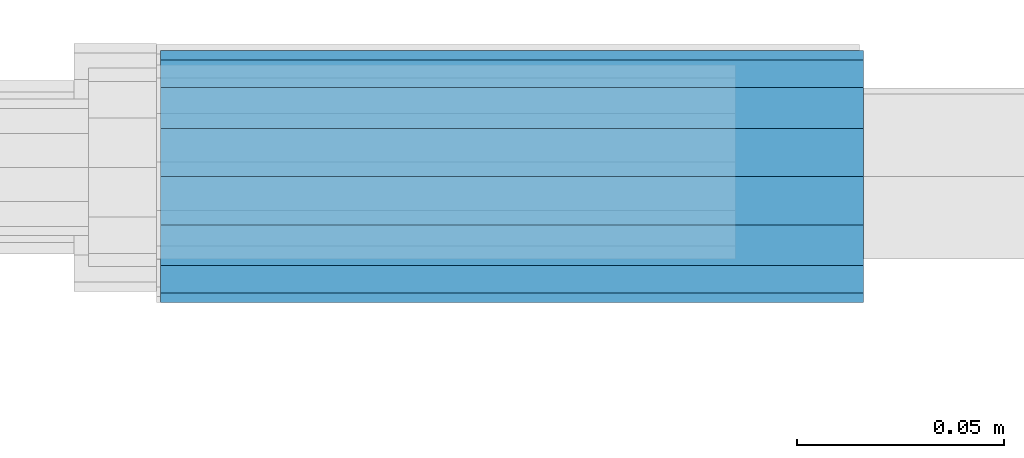
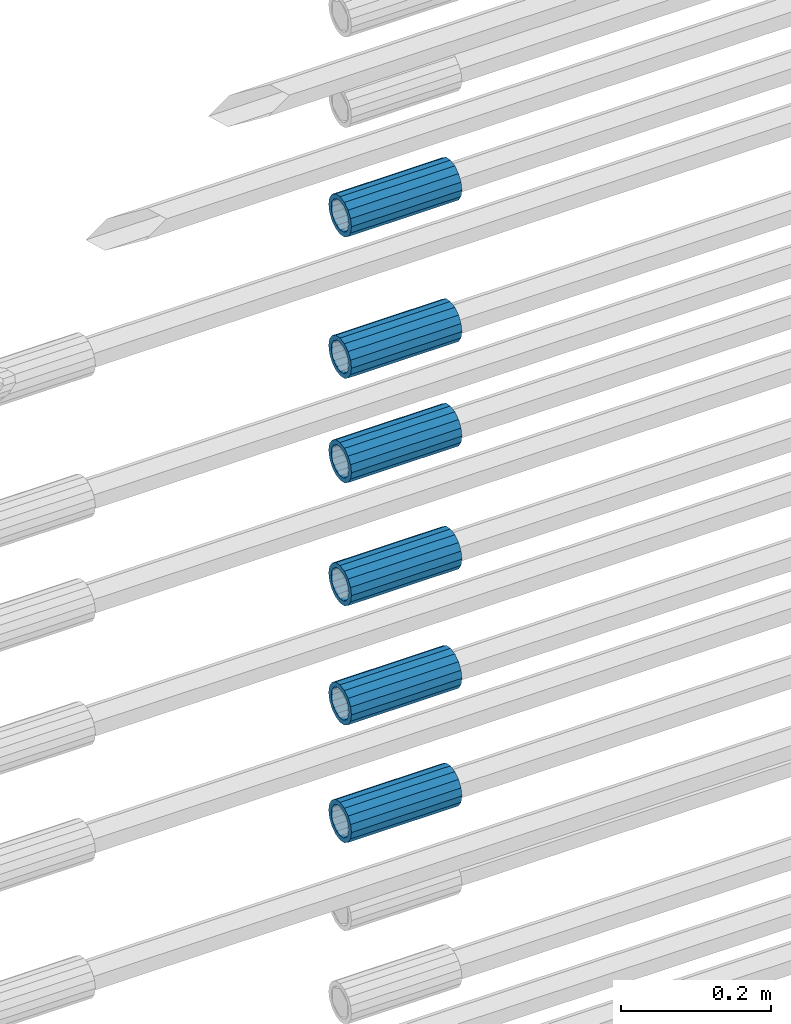
# One storey, part 13 of 119: 6 beams.
"""IFC2X3 building model written with IfcOpenShell, lengths in millimetres."""

from ifc_helpers import new_model, si_unit, frame, origin_with_axes, place, context, subcontext, project, spatial, faceted_brep, material, type_object, element, save


model = new_model("IFC2X3")

# Units and contexts
model_context = context("Model", 3, precision=1e-05, world=origin_with_axes())
body_context = subcontext(model_context, "Body", "Model", "MODEL_VIEW")
ifc_project = project(units=[si_unit("LENGTHUNIT", "METRE", prefix="MILLI"), si_unit("AREAUNIT", "SQUARE_METRE"), si_unit("VOLUMEUNIT", "CUBIC_METRE"), si_unit("MASSUNIT", "GRAM", prefix="KILO"), si_unit("TIMEUNIT", "SECOND"), si_unit("PLANEANGLEUNIT", "RADIAN"), si_unit("SOLIDANGLEUNIT", "STERADIAN"), si_unit("THERMODYNAMICTEMPERATUREUNIT", "DEGREE_CELSIUS"), si_unit("LUMINOUSINTENSITYUNIT", "LUMEN")], contexts=[model_context])

# Site, building, storey
site_placement = place(None, origin_with_axes())
site = spatial("IfcSite", under=ifc_project, at=site_placement, CompositionType="ELEMENT")
building_placement = place(site_placement, origin_with_axes())
building = spatial("IfcBuilding", under=site, at=building_placement, Name="Undefined", CompositionType="ELEMENT")
storey_placement = place(building_placement, origin_with_axes())
storey = spatial("IfcBuildingStorey", under=building, at=storey_placement, Name="Undefined", CompositionType="ELEMENT", Elevation=0.0)

# Beams
ifc_material = material(Name="STEEL/S275")
beam_type = type_object("IfcBeamType", PredefinedType="NOTDEFINED")
beam_1_placement = place(storey_placement, frame((2032020.00007889, 6206399.98994599, 21049.6893060789), z_axis=(0.0, 0.0, 1.0), x_axis=(-0.99999999999998, 1.98000110685822e-07, 0.0)))
element("IfcBeam", 1, at=beam_1_placement, inside=storey, type_object=beam_type, material=ifc_material, Name="AG40N", context=body_context, shape_type="Brep", body=[
    faceted_brep([(1.62981450557709e-09, -23.4999999990687, 0.0), (7.45058059692383e-09, -21.7111690142192, 8.99306066057534), (170.000002125278, -21.711168999318, 8.99306066022245), (170.000002127141, -23.4999999844003, -3.66071617463604e-10), (4.65661287307739e-09, -16.6170093587134, 16.6170093578889), (170.000002122484, -16.6170093440451, 16.6170093575288), (1.86264514923096e-09, -8.99306066217832, 21.7111690140277), (170.000002118759, -8.99306064750999, 21.7111690136603), (2.3283064365387e-10, 9.31322574615479e-10, 23.5), (170.000002114102, 1.28056854009628e-08, 23.4999999996485), (-6.51925802230835e-09, 8.99306065868586, 21.7111690140241), (170.00000211224, 8.99306067335419, 21.7111690136639), (-7.45058059692383e-09, 16.6170093561523, 16.6170093578853), (170.000002109446, 16.6170093708206, 16.6170093575324), (-9.31322574615479e-09, 21.711169013055, 8.99306066057534), (170.000002108514, 21.7111690277234, 8.99306066022245), (-1.16415321826935e-09, 23.5000000009313, 0.0), (170.000002108514, 23.5000000144355, -3.66071617463604e-10), (-8.38190317153931e-09, 21.7111690151505, -8.99306066059444), (170.000002110377, 21.7111690300517, -8.9930606609546), (-5.58793544769287e-09, 16.6170093598776, -16.6170093579008), (170.000002113171, 16.6170093745459, -16.6170093582609), (-9.31322574615479e-10, 8.99306066334248, -21.7111690140396), (170.000002115965, 8.99306067801081, -21.7111690143961), (2.3283064365387e-10, 9.31322574615479e-10, -23.5), (170.00000211969, 1.7927959561348e-08, -23.5000000003843), (5.58793544769287e-09, -8.99306065752171, -21.7111690140396), (170.000002123415, -8.99306064285338, -21.7111690143961), (8.38190317153931e-09, -16.6170093549881, -16.6170093579008), (170.000002125278, -16.6170093403198, -16.6170093582646), (9.31322574615479e-09, -21.7111690121237, -8.99306066059444), (170.000002127141, -21.7111689972226, -8.9930606609546), (1.11758708953857e-08, -30.4999999990687, -9.54969436861575e-12), (1.30385160446167e-08, -28.1783257392235, -11.6718446871514), (170.000002129003, -28.1783257243223, -11.6718446875116), (170.000002129935, -30.4999999841675, -3.66071617463604e-10), (1.02445483207703e-08, -21.5667568228673, -21.5667568262129), (170.000002128072, -21.566756808199, -21.5667568265694), (7.45058059692383e-09, -11.6718446831219, -28.1783257416196), (170.000002125278, -11.6718446684536, -28.1783257419834), (3.72529029846191e-09, 3.95812094211578e-09, -30.5000000000277), (170.00000211969, 1.83936208486557e-08, -30.5000000003879), (-9.31322574615479e-10, 11.6718446905725, -28.1783257416232), (170.000002115965, 11.6718447052408, -28.1783257419797), (-6.51925802230835e-09, 21.5667568286881, -21.5667568262093), (170.000002110377, 21.5667568433564, -21.5667568265694), (-9.31322574615479e-09, 28.178325742716, -11.6718446871478), (170.000002108514, 28.1783257573843, -11.6718446875079), (-1.21071934700012e-08, 30.5, -5.91171556152403e-12), (170.000002106652, 30.5000000144355, -3.62433638656512e-10), (-1.21071934700012e-08, 28.1783257401548, 11.6718446871359), (170.00000210572, 28.1783257548232, 11.6718446867794), (-1.02445483207703e-08, 21.5667568240315, 21.5667568261974), (170.000002107583, 21.566756838467, 21.5667568258409), (-7.45058059692383e-09, 11.671844684286, 28.1783257416041), (170.000002110377, 11.6718446989544, 28.178325741244), (-2.79396772384644e-09, -2.56113708019257e-09, 30.5000000000159), (170.000002114102, 1.18743628263474e-08, 30.4999999996558), (1.86264514923096e-09, -11.6718446896411, 28.1783257416114), (170.000002118759, -11.67184467474, 28.178325741244), (7.45058059692383e-09, -21.5667568275239, 21.5667568261974), (170.000002123415, -21.5667568126228, 21.5667568258373), (1.02445483207703e-08, -28.1783257415518, 11.6718446871359), (170.000002127141, -28.1783257271163, 11.6718446867794)], [[[0, 1, 2, 3]], [[1, 4, 5, 2]], [[4, 6, 7, 5]], [[6, 8, 9, 7]], [[8, 10, 11, 9]], [[10, 12, 13, 11]], [[12, 14, 15, 13]], [[14, 16, 17, 15]], [[16, 18, 19, 17]], [[18, 20, 21, 19]], [[20, 22, 23, 21]], [[22, 24, 25, 23]], [[24, 26, 27, 25]], [[26, 28, 29, 27]], [[28, 30, 31, 29]], [[30, 0, 3, 31]], [[32, 33, 34, 35]], [[33, 36, 37, 34]], [[36, 38, 39, 37]], [[38, 40, 41, 39]], [[40, 42, 43, 41]], [[42, 44, 45, 43]], [[44, 46, 47, 45]], [[46, 48, 49, 47]], [[48, 50, 51, 49]], [[50, 52, 53, 51]], [[52, 54, 55, 53]], [[54, 56, 57, 55]], [[56, 58, 59, 57]], [[58, 60, 61, 59]], [[60, 62, 63, 61]], [[62, 32, 35, 63]], [[37, 39, 41, 43, 45, 47, 49, 51, 53, 55, 57, 59, 61, 63, 35, 34], [5, 7, 9, 11, 13, 15, 17, 19, 21, 23, 25, 27, 29, 31, 3, 2]], [[62, 60, 58, 56, 54, 52, 50, 48, 46, 44, 42, 40, 38, 36, 33, 32], [30, 28, 26, 24, 22, 20, 18, 16, 14, 12, 10, 8, 6, 4, 1, 0]]]),
])
beam_2_placement = place(storey_placement, frame((2032020.00007889, 6206399.98994599, 21240.9893060789), z_axis=(0.0, 0.0, 1.0), x_axis=(-0.99999999999998, 1.98000110685822e-07, 0.0)))
element("IfcBeam", 2, at=beam_2_placement, inside=storey, type_object=beam_type, material=ifc_material, Name="AG40N", context=body_context, shape_type="Brep", body=[
    faceted_brep([(1.62981450557709e-09, -23.4999999990687, 0.0), (7.45058059692383e-09, -21.7111690142192, 8.99306066057534), (170.000002125278, -21.711168999318, 8.99306066022245), (170.000002127141, -23.4999999844003, -3.66071617463604e-10), (4.65661287307739e-09, -16.6170093587134, 16.6170093578889), (170.000002122484, -16.6170093440451, 16.6170093575288), (1.86264514923096e-09, -8.99306066217832, 21.7111690140277), (170.000002118759, -8.99306064750999, 21.7111690136603), (2.3283064365387e-10, 9.31322574615479e-10, 23.5), (170.000002114102, 1.28056854009628e-08, 23.4999999996485), (-6.51925802230835e-09, 8.99306065868586, 21.7111690140241), (170.00000211224, 8.99306067335419, 21.7111690136639), (-7.45058059692383e-09, 16.6170093561523, 16.6170093578853), (170.000002109446, 16.6170093708206, 16.6170093575324), (-9.31322574615479e-09, 21.711169013055, 8.99306066057534), (170.000002108514, 21.7111690277234, 8.99306066022245), (-1.16415321826935e-09, 23.5000000009313, 0.0), (170.000002108514, 23.5000000144355, -3.66071617463604e-10), (-8.38190317153931e-09, 21.7111690151505, -8.99306066059444), (170.000002110377, 21.7111690300517, -8.9930606609546), (-5.58793544769287e-09, 16.6170093598776, -16.6170093579008), (170.000002113171, 16.6170093745459, -16.6170093582609), (-9.31322574615479e-10, 8.99306066334248, -21.7111690140396), (170.000002115965, 8.99306067801081, -21.7111690143961), (2.3283064365387e-10, 9.31322574615479e-10, -23.5), (170.00000211969, 1.7927959561348e-08, -23.5000000003843), (5.58793544769287e-09, -8.99306065752171, -21.7111690140396), (170.000002123415, -8.99306064285338, -21.7111690143961), (8.38190317153931e-09, -16.6170093549881, -16.6170093579008), (170.000002125278, -16.6170093403198, -16.6170093582646), (9.31322574615479e-09, -21.7111690121237, -8.99306066059444), (170.000002127141, -21.7111689972226, -8.9930606609546), (1.11758708953857e-08, -30.4999999990687, -9.54969436861575e-12), (1.30385160446167e-08, -28.1783257392235, -11.6718446871514), (170.000002129003, -28.1783257243223, -11.6718446875116), (170.000002129935, -30.4999999841675, -3.66071617463604e-10), (1.02445483207703e-08, -21.5667568228673, -21.5667568262129), (170.000002128072, -21.566756808199, -21.5667568265694), (7.45058059692383e-09, -11.6718446831219, -28.1783257416196), (170.000002125278, -11.6718446684536, -28.1783257419834), (3.72529029846191e-09, 3.95812094211578e-09, -30.5000000000277), (170.00000211969, 1.83936208486557e-08, -30.5000000003879), (-9.31322574615479e-10, 11.6718446905725, -28.1783257416232), (170.000002115965, 11.6718447052408, -28.1783257419797), (-6.51925802230835e-09, 21.5667568286881, -21.5667568262093), (170.000002110377, 21.5667568433564, -21.5667568265694), (-9.31322574615479e-09, 28.178325742716, -11.6718446871478), (170.000002108514, 28.1783257573843, -11.6718446875079), (-1.21071934700012e-08, 30.5, -5.91171556152403e-12), (170.000002106652, 30.5000000144355, -3.62433638656512e-10), (-1.21071934700012e-08, 28.1783257401548, 11.6718446871359), (170.00000210572, 28.1783257548232, 11.6718446867794), (-1.02445483207703e-08, 21.5667568240315, 21.5667568261974), (170.000002107583, 21.566756838467, 21.5667568258409), (-7.45058059692383e-09, 11.671844684286, 28.1783257416041), (170.000002110377, 11.6718446989544, 28.178325741244), (-2.79396772384644e-09, -2.56113708019257e-09, 30.5000000000159), (170.000002114102, 1.18743628263474e-08, 30.4999999996558), (1.86264514923096e-09, -11.6718446896411, 28.1783257416114), (170.000002118759, -11.67184467474, 28.178325741244), (7.45058059692383e-09, -21.5667568275239, 21.5667568261974), (170.000002123415, -21.5667568126228, 21.5667568258373), (1.02445483207703e-08, -28.1783257415518, 11.6718446871359), (170.000002127141, -28.1783257271163, 11.6718446867794)], [[[0, 1, 2, 3]], [[1, 4, 5, 2]], [[4, 6, 7, 5]], [[6, 8, 9, 7]], [[8, 10, 11, 9]], [[10, 12, 13, 11]], [[12, 14, 15, 13]], [[14, 16, 17, 15]], [[16, 18, 19, 17]], [[18, 20, 21, 19]], [[20, 22, 23, 21]], [[22, 24, 25, 23]], [[24, 26, 27, 25]], [[26, 28, 29, 27]], [[28, 30, 31, 29]], [[30, 0, 3, 31]], [[32, 33, 34, 35]], [[33, 36, 37, 34]], [[36, 38, 39, 37]], [[38, 40, 41, 39]], [[40, 42, 43, 41]], [[42, 44, 45, 43]], [[44, 46, 47, 45]], [[46, 48, 49, 47]], [[48, 50, 51, 49]], [[50, 52, 53, 51]], [[52, 54, 55, 53]], [[54, 56, 57, 55]], [[56, 58, 59, 57]], [[58, 60, 61, 59]], [[60, 62, 63, 61]], [[62, 32, 35, 63]], [[37, 39, 41, 43, 45, 47, 49, 51, 53, 55, 57, 59, 61, 63, 35, 34], [5, 7, 9, 11, 13, 15, 17, 19, 21, 23, 25, 27, 29, 31, 3, 2]], [[62, 60, 58, 56, 54, 52, 50, 48, 46, 44, 42, 40, 38, 36, 33, 32], [30, 28, 26, 24, 22, 20, 18, 16, 14, 12, 10, 8, 6, 4, 1, 0]]]),
])
beam_3_placement = place(storey_placement, frame((2032020.00007889, 6206399.98994599, 21434.9893060789), z_axis=(0.0, 0.0, 1.0), x_axis=(-0.99999999999998, 1.98000110685822e-07, 0.0)))
element("IfcBeam", 3, at=beam_3_placement, inside=storey, type_object=beam_type, material=ifc_material, Name="AG40N", context=body_context, shape_type="Brep", body=[
    faceted_brep([(1.62981450557709e-09, -23.4999999990687, 0.0), (7.45058059692383e-09, -21.7111690142192, 8.99306066057534), (170.000002125278, -21.711168999318, 8.99306066022245), (170.000002127141, -23.4999999844003, -3.66071617463604e-10), (4.65661287307739e-09, -16.6170093587134, 16.6170093578889), (170.000002122484, -16.6170093440451, 16.6170093575288), (1.86264514923096e-09, -8.99306066217832, 21.7111690140277), (170.000002118759, -8.99306064750999, 21.7111690136603), (2.3283064365387e-10, 9.31322574615479e-10, 23.5), (170.000002114102, 1.28056854009628e-08, 23.4999999996485), (-6.51925802230835e-09, 8.99306065868586, 21.7111690140241), (170.00000211224, 8.99306067335419, 21.7111690136639), (-7.45058059692383e-09, 16.6170093561523, 16.6170093578853), (170.000002109446, 16.6170093708206, 16.6170093575324), (-9.31322574615479e-09, 21.711169013055, 8.99306066057534), (170.000002108514, 21.7111690277234, 8.99306066022245), (-1.16415321826935e-09, 23.5000000009313, 0.0), (170.000002108514, 23.5000000144355, -3.66071617463604e-10), (-8.38190317153931e-09, 21.7111690151505, -8.99306066059444), (170.000002110377, 21.7111690300517, -8.9930606609546), (-5.58793544769287e-09, 16.6170093598776, -16.6170093579008), (170.000002113171, 16.6170093745459, -16.6170093582609), (-9.31322574615479e-10, 8.99306066334248, -21.7111690140396), (170.000002115965, 8.99306067801081, -21.7111690143961), (2.3283064365387e-10, 9.31322574615479e-10, -23.5), (170.00000211969, 1.7927959561348e-08, -23.5000000003843), (5.58793544769287e-09, -8.99306065752171, -21.7111690140396), (170.000002123415, -8.99306064285338, -21.7111690143961), (8.38190317153931e-09, -16.6170093549881, -16.6170093579008), (170.000002125278, -16.6170093403198, -16.6170093582646), (9.31322574615479e-09, -21.7111690121237, -8.99306066059444), (170.000002127141, -21.7111689972226, -8.9930606609546), (1.11758708953857e-08, -30.4999999990687, -9.54969436861575e-12), (1.30385160446167e-08, -28.1783257392235, -11.6718446871514), (170.000002129003, -28.1783257243223, -11.6718446875116), (170.000002129935, -30.4999999841675, -3.66071617463604e-10), (1.02445483207703e-08, -21.5667568228673, -21.5667568262129), (170.000002128072, -21.566756808199, -21.5667568265694), (7.45058059692383e-09, -11.6718446831219, -28.1783257416196), (170.000002125278, -11.6718446684536, -28.1783257419834), (3.72529029846191e-09, 3.95812094211578e-09, -30.5000000000277), (170.00000211969, 1.83936208486557e-08, -30.5000000003879), (-9.31322574615479e-10, 11.6718446905725, -28.1783257416232), (170.000002115965, 11.6718447052408, -28.1783257419797), (-6.51925802230835e-09, 21.5667568286881, -21.5667568262093), (170.000002110377, 21.5667568433564, -21.5667568265694), (-9.31322574615479e-09, 28.178325742716, -11.6718446871478), (170.000002108514, 28.1783257573843, -11.6718446875079), (-1.21071934700012e-08, 30.5, -5.91171556152403e-12), (170.000002106652, 30.5000000144355, -3.62433638656512e-10), (-1.21071934700012e-08, 28.1783257401548, 11.6718446871359), (170.00000210572, 28.1783257548232, 11.6718446867794), (-1.02445483207703e-08, 21.5667568240315, 21.5667568261974), (170.000002107583, 21.566756838467, 21.5667568258409), (-7.45058059692383e-09, 11.671844684286, 28.1783257416041), (170.000002110377, 11.6718446989544, 28.178325741244), (-2.79396772384644e-09, -2.56113708019257e-09, 30.5000000000159), (170.000002114102, 1.18743628263474e-08, 30.4999999996558), (1.86264514923096e-09, -11.6718446896411, 28.1783257416114), (170.000002118759, -11.67184467474, 28.178325741244), (7.45058059692383e-09, -21.5667568275239, 21.5667568261974), (170.000002123415, -21.5667568126228, 21.5667568258373), (1.02445483207703e-08, -28.1783257415518, 11.6718446871359), (170.000002127141, -28.1783257271163, 11.6718446867794)], [[[0, 1, 2, 3]], [[1, 4, 5, 2]], [[4, 6, 7, 5]], [[6, 8, 9, 7]], [[8, 10, 11, 9]], [[10, 12, 13, 11]], [[12, 14, 15, 13]], [[14, 16, 17, 15]], [[16, 18, 19, 17]], [[18, 20, 21, 19]], [[20, 22, 23, 21]], [[22, 24, 25, 23]], [[24, 26, 27, 25]], [[26, 28, 29, 27]], [[28, 30, 31, 29]], [[30, 0, 3, 31]], [[32, 33, 34, 35]], [[33, 36, 37, 34]], [[36, 38, 39, 37]], [[38, 40, 41, 39]], [[40, 42, 43, 41]], [[42, 44, 45, 43]], [[44, 46, 47, 45]], [[46, 48, 49, 47]], [[48, 50, 51, 49]], [[50, 52, 53, 51]], [[52, 54, 55, 53]], [[54, 56, 57, 55]], [[56, 58, 59, 57]], [[58, 60, 61, 59]], [[60, 62, 63, 61]], [[62, 32, 35, 63]], [[37, 39, 41, 43, 45, 47, 49, 51, 53, 55, 57, 59, 61, 63, 35, 34], [5, 7, 9, 11, 13, 15, 17, 19, 21, 23, 25, 27, 29, 31, 3, 2]], [[62, 60, 58, 56, 54, 52, 50, 48, 46, 44, 42, 40, 38, 36, 33, 32], [30, 28, 26, 24, 22, 20, 18, 16, 14, 12, 10, 8, 6, 4, 1, 0]]]),
])
beam_4_placement = place(storey_placement, frame((2032020.00007889, 6206399.98994599, 21634.9893060789), z_axis=(0.0, 0.0, 1.0), x_axis=(-0.99999999999998, 1.98000110685822e-07, 0.0)))
element("IfcBeam", 4, at=beam_4_placement, inside=storey, type_object=beam_type, material=ifc_material, Name="AG40N", context=body_context, shape_type="Brep", body=[
    faceted_brep([(1.62981450557709e-09, -23.4999999990687, 0.0), (7.45058059692383e-09, -21.7111690142192, 8.99306066057534), (170.000002125278, -21.711168999318, 8.99306066022245), (170.000002127141, -23.4999999844003, -3.66071617463604e-10), (4.65661287307739e-09, -16.6170093587134, 16.6170093578889), (170.000002122484, -16.6170093440451, 16.6170093575288), (1.86264514923096e-09, -8.99306066217832, 21.7111690140277), (170.000002118759, -8.99306064750999, 21.7111690136603), (2.3283064365387e-10, 9.31322574615479e-10, 23.5), (170.000002114102, 1.28056854009628e-08, 23.4999999996485), (-6.51925802230835e-09, 8.99306065868586, 21.7111690140241), (170.00000211224, 8.99306067335419, 21.7111690136639), (-7.45058059692383e-09, 16.6170093561523, 16.6170093578853), (170.000002109446, 16.6170093708206, 16.6170093575324), (-9.31322574615479e-09, 21.711169013055, 8.99306066057534), (170.000002108514, 21.7111690277234, 8.99306066022245), (-1.16415321826935e-09, 23.5000000009313, 0.0), (170.000002108514, 23.5000000144355, -3.66071617463604e-10), (-8.38190317153931e-09, 21.7111690151505, -8.99306066059444), (170.000002110377, 21.7111690300517, -8.9930606609546), (-5.58793544769287e-09, 16.6170093598776, -16.6170093579008), (170.000002113171, 16.6170093745459, -16.6170093582609), (-9.31322574615479e-10, 8.99306066334248, -21.7111690140396), (170.000002115965, 8.99306067801081, -21.7111690143961), (2.3283064365387e-10, 9.31322574615479e-10, -23.5), (170.00000211969, 1.7927959561348e-08, -23.5000000003843), (5.58793544769287e-09, -8.99306065752171, -21.7111690140396), (170.000002123415, -8.99306064285338, -21.7111690143961), (8.38190317153931e-09, -16.6170093549881, -16.6170093579008), (170.000002125278, -16.6170093403198, -16.6170093582646), (9.31322574615479e-09, -21.7111690121237, -8.99306066059444), (170.000002127141, -21.7111689972226, -8.9930606609546), (1.11758708953857e-08, -30.4999999990687, -9.54969436861575e-12), (1.30385160446167e-08, -28.1783257392235, -11.6718446871514), (170.000002129003, -28.1783257243223, -11.6718446875116), (170.000002129935, -30.4999999841675, -3.66071617463604e-10), (1.02445483207703e-08, -21.5667568228673, -21.5667568262129), (170.000002128072, -21.566756808199, -21.5667568265694), (7.45058059692383e-09, -11.6718446831219, -28.1783257416196), (170.000002125278, -11.6718446684536, -28.1783257419834), (3.72529029846191e-09, 3.95812094211578e-09, -30.5000000000277), (170.00000211969, 1.83936208486557e-08, -30.5000000003879), (-9.31322574615479e-10, 11.6718446905725, -28.1783257416232), (170.000002115965, 11.6718447052408, -28.1783257419797), (-6.51925802230835e-09, 21.5667568286881, -21.5667568262093), (170.000002110377, 21.5667568433564, -21.5667568265694), (-9.31322574615479e-09, 28.178325742716, -11.6718446871478), (170.000002108514, 28.1783257573843, -11.6718446875079), (-1.21071934700012e-08, 30.5, -5.91171556152403e-12), (170.000002106652, 30.5000000144355, -3.62433638656512e-10), (-1.21071934700012e-08, 28.1783257401548, 11.6718446871359), (170.00000210572, 28.1783257548232, 11.6718446867794), (-1.02445483207703e-08, 21.5667568240315, 21.5667568261974), (170.000002107583, 21.566756838467, 21.5667568258409), (-7.45058059692383e-09, 11.671844684286, 28.1783257416041), (170.000002110377, 11.6718446989544, 28.178325741244), (-2.79396772384644e-09, -2.56113708019257e-09, 30.5000000000159), (170.000002114102, 1.18743628263474e-08, 30.4999999996558), (1.86264514923096e-09, -11.6718446896411, 28.1783257416114), (170.000002118759, -11.67184467474, 28.178325741244), (7.45058059692383e-09, -21.5667568275239, 21.5667568261974), (170.000002123415, -21.5667568126228, 21.5667568258373), (1.02445483207703e-08, -28.1783257415518, 11.6718446871359), (170.000002127141, -28.1783257271163, 11.6718446867794)], [[[0, 1, 2, 3]], [[1, 4, 5, 2]], [[4, 6, 7, 5]], [[6, 8, 9, 7]], [[8, 10, 11, 9]], [[10, 12, 13, 11]], [[12, 14, 15, 13]], [[14, 16, 17, 15]], [[16, 18, 19, 17]], [[18, 20, 21, 19]], [[20, 22, 23, 21]], [[22, 24, 25, 23]], [[24, 26, 27, 25]], [[26, 28, 29, 27]], [[28, 30, 31, 29]], [[30, 0, 3, 31]], [[32, 33, 34, 35]], [[33, 36, 37, 34]], [[36, 38, 39, 37]], [[38, 40, 41, 39]], [[40, 42, 43, 41]], [[42, 44, 45, 43]], [[44, 46, 47, 45]], [[46, 48, 49, 47]], [[48, 50, 51, 49]], [[50, 52, 53, 51]], [[52, 54, 55, 53]], [[54, 56, 57, 55]], [[56, 58, 59, 57]], [[58, 60, 61, 59]], [[60, 62, 63, 61]], [[62, 32, 35, 63]], [[37, 39, 41, 43, 45, 47, 49, 51, 53, 55, 57, 59, 61, 63, 35, 34], [5, 7, 9, 11, 13, 15, 17, 19, 21, 23, 25, 27, 29, 31, 3, 2]], [[62, 60, 58, 56, 54, 52, 50, 48, 46, 44, 42, 40, 38, 36, 33, 32], [30, 28, 26, 24, 22, 20, 18, 16, 14, 12, 10, 8, 6, 4, 1, 0]]]),
])
beam_5_placement = place(storey_placement, frame((2032020.00007889, 6206399.98994599, 21804.9893060789), z_axis=(0.0, 0.0, 1.0), x_axis=(-0.99999999999998, 1.98000110685822e-07, 0.0)))
element("IfcBeam", 5, at=beam_5_placement, inside=storey, type_object=beam_type, material=ifc_material, Name="AG40N", context=body_context, shape_type="Brep", body=[
    faceted_brep([(1.62981450557709e-09, -23.4999999990687, 0.0), (7.45058059692383e-09, -21.7111690142192, 8.99306066057534), (170.000002125278, -21.711168999318, 8.99306066022245), (170.000002127141, -23.4999999844003, -3.66071617463604e-10), (4.65661287307739e-09, -16.6170093587134, 16.6170093578889), (170.000002122484, -16.6170093440451, 16.6170093575288), (1.86264514923096e-09, -8.99306066217832, 21.7111690140277), (170.000002118759, -8.99306064750999, 21.7111690136603), (2.3283064365387e-10, 9.31322574615479e-10, 23.5), (170.000002114102, 1.28056854009628e-08, 23.4999999996485), (-6.51925802230835e-09, 8.99306065868586, 21.7111690140241), (170.00000211224, 8.99306067335419, 21.7111690136639), (-7.45058059692383e-09, 16.6170093561523, 16.6170093578853), (170.000002109446, 16.6170093708206, 16.6170093575324), (-9.31322574615479e-09, 21.711169013055, 8.99306066057534), (170.000002108514, 21.7111690277234, 8.99306066022245), (-1.16415321826935e-09, 23.5000000009313, 0.0), (170.000002108514, 23.5000000144355, -3.66071617463604e-10), (-8.38190317153931e-09, 21.7111690151505, -8.99306066059444), (170.000002110377, 21.7111690300517, -8.9930606609546), (-5.58793544769287e-09, 16.6170093598776, -16.6170093579008), (170.000002113171, 16.6170093745459, -16.6170093582609), (-9.31322574615479e-10, 8.99306066334248, -21.7111690140396), (170.000002115965, 8.99306067801081, -21.7111690143961), (2.3283064365387e-10, 9.31322574615479e-10, -23.5), (170.00000211969, 1.7927959561348e-08, -23.5000000003843), (5.58793544769287e-09, -8.99306065752171, -21.7111690140396), (170.000002123415, -8.99306064285338, -21.7111690143961), (8.38190317153931e-09, -16.6170093549881, -16.6170093579008), (170.000002125278, -16.6170093403198, -16.6170093582646), (9.31322574615479e-09, -21.7111690121237, -8.99306066059444), (170.000002127141, -21.7111689972226, -8.9930606609546), (1.11758708953857e-08, -30.4999999990687, -9.54969436861575e-12), (1.30385160446167e-08, -28.1783257392235, -11.6718446871514), (170.000002129003, -28.1783257243223, -11.6718446875116), (170.000002129935, -30.4999999841675, -3.66071617463604e-10), (1.02445483207703e-08, -21.5667568228673, -21.5667568262129), (170.000002128072, -21.566756808199, -21.5667568265694), (7.45058059692383e-09, -11.6718446831219, -28.1783257416196), (170.000002125278, -11.6718446684536, -28.1783257419834), (3.72529029846191e-09, 3.95812094211578e-09, -30.5000000000277), (170.00000211969, 1.83936208486557e-08, -30.5000000003879), (-9.31322574615479e-10, 11.6718446905725, -28.1783257416232), (170.000002115965, 11.6718447052408, -28.1783257419797), (-6.51925802230835e-09, 21.5667568286881, -21.5667568262093), (170.000002110377, 21.5667568433564, -21.5667568265694), (-9.31322574615479e-09, 28.178325742716, -11.6718446871478), (170.000002108514, 28.1783257573843, -11.6718446875079), (-1.21071934700012e-08, 30.5, -5.91171556152403e-12), (170.000002106652, 30.5000000144355, -3.62433638656512e-10), (-1.21071934700012e-08, 28.1783257401548, 11.6718446871359), (170.00000210572, 28.1783257548232, 11.6718446867794), (-1.02445483207703e-08, 21.5667568240315, 21.5667568261974), (170.000002107583, 21.566756838467, 21.5667568258409), (-7.45058059692383e-09, 11.671844684286, 28.1783257416041), (170.000002110377, 11.6718446989544, 28.178325741244), (-2.79396772384644e-09, -2.56113708019257e-09, 30.5000000000159), (170.000002114102, 1.18743628263474e-08, 30.4999999996558), (1.86264514923096e-09, -11.6718446896411, 28.1783257416114), (170.000002118759, -11.67184467474, 28.178325741244), (7.45058059692383e-09, -21.5667568275239, 21.5667568261974), (170.000002123415, -21.5667568126228, 21.5667568258373), (1.02445483207703e-08, -28.1783257415518, 11.6718446871359), (170.000002127141, -28.1783257271163, 11.6718446867794)], [[[0, 1, 2, 3]], [[1, 4, 5, 2]], [[4, 6, 7, 5]], [[6, 8, 9, 7]], [[8, 10, 11, 9]], [[10, 12, 13, 11]], [[12, 14, 15, 13]], [[14, 16, 17, 15]], [[16, 18, 19, 17]], [[18, 20, 21, 19]], [[20, 22, 23, 21]], [[22, 24, 25, 23]], [[24, 26, 27, 25]], [[26, 28, 29, 27]], [[28, 30, 31, 29]], [[30, 0, 3, 31]], [[32, 33, 34, 35]], [[33, 36, 37, 34]], [[36, 38, 39, 37]], [[38, 40, 41, 39]], [[40, 42, 43, 41]], [[42, 44, 45, 43]], [[44, 46, 47, 45]], [[46, 48, 49, 47]], [[48, 50, 51, 49]], [[50, 52, 53, 51]], [[52, 54, 55, 53]], [[54, 56, 57, 55]], [[56, 58, 59, 57]], [[58, 60, 61, 59]], [[60, 62, 63, 61]], [[62, 32, 35, 63]], [[37, 39, 41, 43, 45, 47, 49, 51, 53, 55, 57, 59, 61, 63, 35, 34], [5, 7, 9, 11, 13, 15, 17, 19, 21, 23, 25, 27, 29, 31, 3, 2]], [[62, 60, 58, 56, 54, 52, 50, 48, 46, 44, 42, 40, 38, 36, 33, 32], [30, 28, 26, 24, 22, 20, 18, 16, 14, 12, 10, 8, 6, 4, 1, 0]]]),
])
beam_6_placement = place(storey_placement, frame((2032020.00007889, 6206399.98994599, 22034.9893060789), z_axis=(0.0, 0.0, 1.0), x_axis=(-0.99999999999998, 1.98000110685822e-07, 0.0)))
element("IfcBeam", 6, at=beam_6_placement, inside=storey, type_object=beam_type, material=ifc_material, Name="AG40N", context=body_context, shape_type="Brep", body=[
    faceted_brep([(1.62981450557709e-09, -23.4999999990687, 0.0), (7.45058059692383e-09, -21.7111690142192, 8.99306066057534), (170.000002125278, -21.711168999318, 8.99306066022245), (170.000002127141, -23.4999999844003, -3.66071617463604e-10), (4.65661287307739e-09, -16.6170093587134, 16.6170093578889), (170.000002122484, -16.6170093440451, 16.6170093575288), (1.86264514923096e-09, -8.99306066217832, 21.7111690140277), (170.000002118759, -8.99306064750999, 21.7111690136603), (2.3283064365387e-10, 9.31322574615479e-10, 23.5), (170.000002114102, 1.28056854009628e-08, 23.4999999996485), (-6.51925802230835e-09, 8.99306065868586, 21.7111690140241), (170.00000211224, 8.99306067335419, 21.7111690136639), (-7.45058059692383e-09, 16.6170093561523, 16.6170093578853), (170.000002109446, 16.6170093708206, 16.6170093575324), (-9.31322574615479e-09, 21.711169013055, 8.99306066057534), (170.000002108514, 21.7111690277234, 8.99306066022245), (-1.16415321826935e-09, 23.5000000009313, 0.0), (170.000002108514, 23.5000000144355, -3.66071617463604e-10), (-8.38190317153931e-09, 21.7111690151505, -8.99306066059444), (170.000002110377, 21.7111690300517, -8.9930606609546), (-5.58793544769287e-09, 16.6170093598776, -16.6170093579008), (170.000002113171, 16.6170093745459, -16.6170093582609), (-9.31322574615479e-10, 8.99306066334248, -21.7111690140396), (170.000002115965, 8.99306067801081, -21.7111690143961), (2.3283064365387e-10, 9.31322574615479e-10, -23.5), (170.00000211969, 1.7927959561348e-08, -23.5000000003843), (5.58793544769287e-09, -8.99306065752171, -21.7111690140396), (170.000002123415, -8.99306064285338, -21.7111690143961), (8.38190317153931e-09, -16.6170093549881, -16.6170093579008), (170.000002125278, -16.6170093403198, -16.6170093582646), (9.31322574615479e-09, -21.7111690121237, -8.99306066059444), (170.000002127141, -21.7111689972226, -8.9930606609546), (1.11758708953857e-08, -30.4999999990687, -9.54969436861575e-12), (1.30385160446167e-08, -28.1783257392235, -11.6718446871514), (170.000002129003, -28.1783257243223, -11.6718446875116), (170.000002129935, -30.4999999841675, -3.66071617463604e-10), (1.02445483207703e-08, -21.5667568228673, -21.5667568262129), (170.000002128072, -21.566756808199, -21.5667568265694), (7.45058059692383e-09, -11.6718446831219, -28.1783257416196), (170.000002125278, -11.6718446684536, -28.1783257419834), (3.72529029846191e-09, 3.95812094211578e-09, -30.5000000000277), (170.00000211969, 1.83936208486557e-08, -30.5000000003879), (-9.31322574615479e-10, 11.6718446905725, -28.1783257416232), (170.000002115965, 11.6718447052408, -28.1783257419797), (-6.51925802230835e-09, 21.5667568286881, -21.5667568262093), (170.000002110377, 21.5667568433564, -21.5667568265694), (-9.31322574615479e-09, 28.178325742716, -11.6718446871478), (170.000002108514, 28.1783257573843, -11.6718446875079), (-1.21071934700012e-08, 30.5, -5.91171556152403e-12), (170.000002106652, 30.5000000144355, -3.62433638656512e-10), (-1.21071934700012e-08, 28.1783257401548, 11.6718446871359), (170.00000210572, 28.1783257548232, 11.6718446867794), (-1.02445483207703e-08, 21.5667568240315, 21.5667568261974), (170.000002107583, 21.566756838467, 21.5667568258409), (-7.45058059692383e-09, 11.671844684286, 28.1783257416041), (170.000002110377, 11.6718446989544, 28.178325741244), (-2.79396772384644e-09, -2.56113708019257e-09, 30.5000000000159), (170.000002114102, 1.18743628263474e-08, 30.4999999996558), (1.86264514923096e-09, -11.6718446896411, 28.1783257416114), (170.000002118759, -11.67184467474, 28.178325741244), (7.45058059692383e-09, -21.5667568275239, 21.5667568261974), (170.000002123415, -21.5667568126228, 21.5667568258373), (1.02445483207703e-08, -28.1783257415518, 11.6718446871359), (170.000002127141, -28.1783257271163, 11.6718446867794)], [[[0, 1, 2, 3]], [[1, 4, 5, 2]], [[4, 6, 7, 5]], [[6, 8, 9, 7]], [[8, 10, 11, 9]], [[10, 12, 13, 11]], [[12, 14, 15, 13]], [[14, 16, 17, 15]], [[16, 18, 19, 17]], [[18, 20, 21, 19]], [[20, 22, 23, 21]], [[22, 24, 25, 23]], [[24, 26, 27, 25]], [[26, 28, 29, 27]], [[28, 30, 31, 29]], [[30, 0, 3, 31]], [[32, 33, 34, 35]], [[33, 36, 37, 34]], [[36, 38, 39, 37]], [[38, 40, 41, 39]], [[40, 42, 43, 41]], [[42, 44, 45, 43]], [[44, 46, 47, 45]], [[46, 48, 49, 47]], [[48, 50, 51, 49]], [[50, 52, 53, 51]], [[52, 54, 55, 53]], [[54, 56, 57, 55]], [[56, 58, 59, 57]], [[58, 60, 61, 59]], [[60, 62, 63, 61]], [[62, 32, 35, 63]], [[37, 39, 41, 43, 45, 47, 49, 51, 53, 55, 57, 59, 61, 63, 35, 34], [5, 7, 9, 11, 13, 15, 17, 19, 21, 23, 25, 27, 29, 31, 3, 2]], [[62, 60, 58, 56, 54, 52, 50, 48, 46, 44, 42, 40, 38, 36, 33, 32], [30, 28, 26, 24, 22, 20, 18, 16, 14, 12, 10, 8, 6, 4, 1, 0]]]),
])

save(model, "model.ifc")
